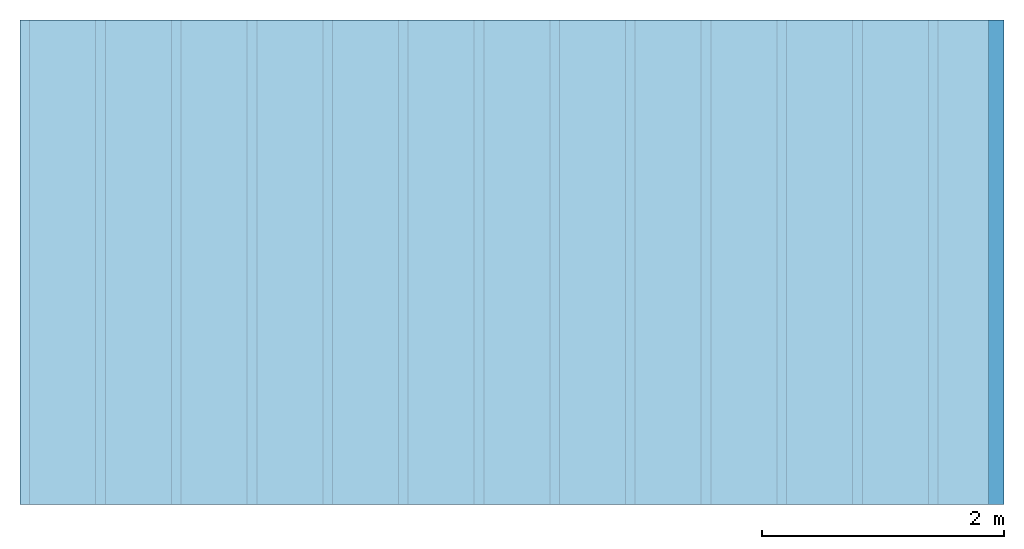
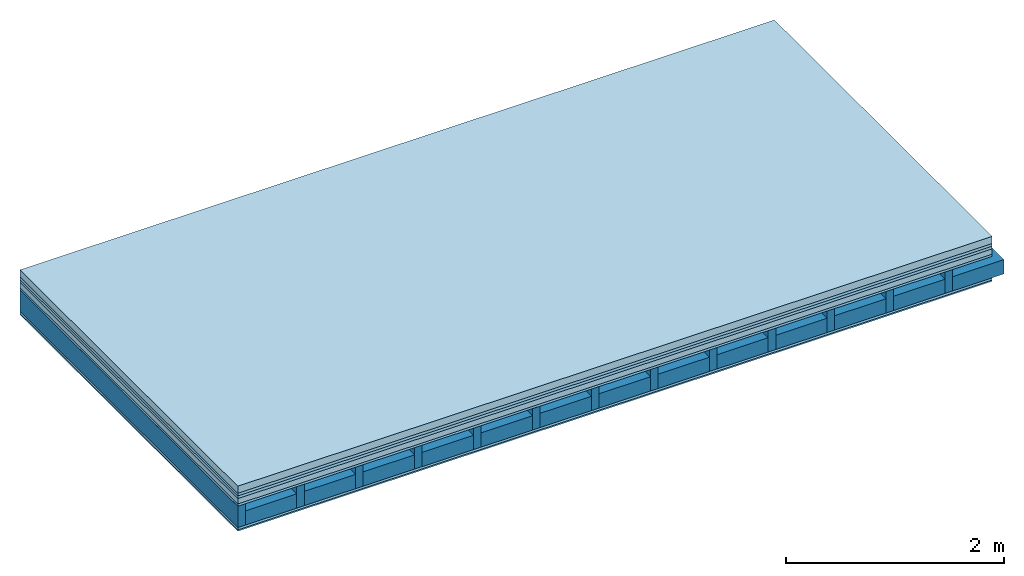
# One storey: 7 plates, 2 members, 1 element without a shape of its own.
"""IFC4 building model written with IfcOpenShell, lengths in metres."""

from ifc_helpers import new_model, si_unit, derived_unit, direction, frame, frame_2d, origin, origin_with_axes, place, context, project, spatial, rectangle, extrude, material, layer, layer_set, type_object, element, aggregate, save


model = new_model("IFC4")

# Units and contexts
plan_context = context("Plan", 3, precision=1e-05, world=origin(), true_north=direction((0.0, 1.0)))
model_context = context("Model", 3, precision=1e-05, world=origin(), true_north=direction((0.0, 1.0)))
ifc_project = project(units=[si_unit("LENGTHUNIT", "METRE"), derived_unit("SOUNDPRESSUREUNIT", [(si_unit("PRESSUREUNIT", "PASCAL", prefix="MICRO"), 0)]), si_unit("ENERGYUNIT", "JOULE", prefix="MEGA"), si_unit("MASSUNIT", "GRAM", prefix="KILO"), derived_unit("THERMALTRANSMITTANCEUNIT", [(si_unit("POWERUNIT", "WATT"), 1), (si_unit("AREAUNIT", "SQUARE_METRE"), -1), (si_unit("THERMODYNAMICTEMPERATUREUNIT", "KELVIN"), -1)]), derived_unit("AREADENSITYUNIT", [(si_unit("MASSUNIT", "GRAM", prefix="KILO"), 1), (si_unit("AREAUNIT", "SQUARE_METRE"), -1)]), derived_unit("USERDEFINED", [(si_unit("ENERGYUNIT", "JOULE", prefix="MEGA"), 1), (si_unit("AREAUNIT", "SQUARE_METRE"), -1)])], contexts=[plan_context, model_context])

# Site, building, storey
site = spatial("IfcSite", under=ifc_project)
building_placement = place(None, origin())
building = spatial("IfcBuilding", under=site, at=building_placement)
storey_placement = place(building_placement, origin())
storey = spatial("IfcBuildingStorey", under=building, at=storey_placement)

# Slab, members, plates
ifc_material_1 = material(Name="Cement screed", Category="04.006")
ifc_layer_1 = layer(ifc_material_1, 0.08, Name="On-material")
ifc_material_2 = material()
ifc_layer_2 = layer(ifc_material_2, 0.03, Name="Impact sound insulation")
ifc_material_3 = material()
ifc_layer_3 = layer(ifc_material_3, 0.03, Name="Additional insulation")
ifc_material_4 = material(Name="Cement panels, glued on sub-floor", Category="02.007")
ifc_layer_4 = layer(ifc_material_4, 0.06, Name="on Supporting structure")
ifc_material_5 = material(Category="07.001")
ifc_layer_5 = layer(ifc_material_5, 0.025, Name="Sub-floor")
ifc_material_6 = material(Name="Rigid, of the art")
ifc_layer_6 = layer(ifc_material_6, 0.0, Name="Bond")
ifc_layer_7 = layer(None, 0.24, Name="Supporting structure")
ifc_layer_8 = layer(ifc_material_6, 0.0, Name="Bond")
ifc_layer_9 = layer(ifc_material_5, 0.025, Name="Lower layer 1")
ifc_material_7 = material(Category="03.007")
ifc_layer_10 = layer(ifc_material_7, 0.015, Name="Lower 2nd layer")
ifc_layer_set = layer_set([ifc_layer_1, ifc_layer_2, ifc_layer_3, ifc_layer_4, ifc_layer_5, ifc_layer_6, ifc_layer_7, ifc_layer_8, ifc_layer_9, ifc_layer_10])
slab_type = type_object("IfcSlabType", Name="A0431", PredefinedType="NOTDEFINED", material=ifc_layer_set)
slab_placement = place(None, frame((0.0, 0.0, 0.0), z_axis=(0.0, 0.0, -1.0), x_axis=(1.0, 0.0, 0.0)))
slab = element("IfcSlab", 1, at=slab_placement, inside=storey, type_object=slab_type, material=ifc_layer_set, Name="Slab #1")
ifc_material_8 = material()
member_1_placement = place(slab_placement, origin())
member_1 = element("IfcMember", 2, at=member_1_placement, material=ifc_material_8, Name="Supporting structure", context=plan_context, shape_type="SweptSolid", body=[
    extrude(rectangle(XDim=0.08, YDim=0.24, at=frame_2d((0.04, 0.12), x_axis=(1.0, 0.0))), frame((0.0, 4.0, 0.225), z_axis=(0.0, -1.0, 0.0), x_axis=(1.0, 0.0, 0.0)), (0.0, 0.0, 1.0), 4.0),
    extrude(rectangle(XDim=0.08, YDim=0.24, at=frame_2d((0.04, 0.12), x_axis=(1.0, 0.0))), frame((0.625, 4.0, 0.225), z_axis=(0.0, -1.0, 0.0), x_axis=(1.0, 0.0, 0.0)), (0.0, 0.0, 1.0), 4.0),
    extrude(rectangle(XDim=0.08, YDim=0.24, at=frame_2d((0.04, 0.12), x_axis=(1.0, 0.0))), frame((1.25, 4.0, 0.225), z_axis=(0.0, -1.0, 0.0), x_axis=(1.0, 0.0, 0.0)), (0.0, 0.0, 1.0), 4.0),
    extrude(rectangle(XDim=0.08, YDim=0.24, at=frame_2d((0.04, 0.12), x_axis=(1.0, 0.0))), frame((1.875, 4.0, 0.225), z_axis=(0.0, -1.0, 0.0), x_axis=(1.0, 0.0, 0.0)), (0.0, 0.0, 1.0), 4.0),
    extrude(rectangle(XDim=0.08, YDim=0.24, at=frame_2d((0.04, 0.12), x_axis=(1.0, 0.0))), frame((2.5, 4.0, 0.225), z_axis=(0.0, -1.0, 0.0), x_axis=(1.0, 0.0, 0.0)), (0.0, 0.0, 1.0), 4.0),
    extrude(rectangle(XDim=0.08, YDim=0.24, at=frame_2d((0.04, 0.12), x_axis=(1.0, 0.0))), frame((3.125, 4.0, 0.225), z_axis=(0.0, -1.0, 0.0), x_axis=(1.0, 0.0, 0.0)), (0.0, 0.0, 1.0), 4.0),
    extrude(rectangle(XDim=0.08, YDim=0.24, at=frame_2d((0.04, 0.12), x_axis=(1.0, 0.0))), frame((3.75, 4.0, 0.225), z_axis=(0.0, -1.0, 0.0), x_axis=(1.0, 0.0, 0.0)), (0.0, 0.0, 1.0), 4.0),
    extrude(rectangle(XDim=0.08, YDim=0.24, at=frame_2d((0.04, 0.12), x_axis=(1.0, 0.0))), frame((4.375, 4.0, 0.225), z_axis=(0.0, -1.0, 0.0), x_axis=(1.0, 0.0, 0.0)), (0.0, 0.0, 1.0), 4.0),
    extrude(rectangle(XDim=0.08, YDim=0.24, at=frame_2d((0.04, 0.12), x_axis=(1.0, 0.0))), frame((5.0, 4.0, 0.225), z_axis=(0.0, -1.0, 0.0), x_axis=(1.0, 0.0, 0.0)), (0.0, 0.0, 1.0), 4.0),
    extrude(rectangle(XDim=0.08, YDim=0.24, at=frame_2d((0.04, 0.12), x_axis=(1.0, 0.0))), frame((5.625, 4.0, 0.225), z_axis=(0.0, -1.0, 0.0), x_axis=(1.0, 0.0, 0.0)), (0.0, 0.0, 1.0), 4.0),
    extrude(rectangle(XDim=0.08, YDim=0.24, at=frame_2d((0.04, 0.12), x_axis=(1.0, 0.0))), frame((6.25, 4.0, 0.225), z_axis=(0.0, -1.0, 0.0), x_axis=(1.0, 0.0, 0.0)), (0.0, 0.0, 1.0), 4.0),
    extrude(rectangle(XDim=0.08, YDim=0.24, at=frame_2d((0.04, 0.12), x_axis=(1.0, 0.0))), frame((6.875, 4.0, 0.225), z_axis=(0.0, -1.0, 0.0), x_axis=(1.0, 0.0, 0.0)), (0.0, 0.0, 1.0), 4.0),
    extrude(rectangle(XDim=0.08, YDim=0.24, at=frame_2d((0.04, 0.12), x_axis=(1.0, 0.0))), frame((7.5, 4.0, 0.225), z_axis=(0.0, -1.0, 0.0), x_axis=(1.0, 0.0, 0.0)), (0.0, 0.0, 1.0), 4.0),
])
ifc_material_9 = material()
member_2_placement = place(slab_placement, origin())
member_2 = element("IfcMember", 3, at=member_2_placement, material=ifc_material_9, Name="Cavity", context=plan_context, shape_type="SweptSolid", body=[
    extrude(rectangle(XDim=0.545, YDim=0.16, at=frame_2d((0.2725, 0.08), x_axis=(1.0, 0.0))), frame((0.08, 4.0, 0.305), z_axis=(0.0, -1.0, 0.0), x_axis=(1.0, 0.0, 0.0)), (0.0, 0.0, 1.0), 4.0),
    extrude(rectangle(XDim=0.545, YDim=0.16, at=frame_2d((0.2725, 0.08), x_axis=(1.0, 0.0))), frame((0.705, 4.0, 0.305), z_axis=(0.0, -1.0, 0.0), x_axis=(1.0, 0.0, 0.0)), (0.0, 0.0, 1.0), 4.0),
    extrude(rectangle(XDim=0.545, YDim=0.16, at=frame_2d((0.2725, 0.08), x_axis=(1.0, 0.0))), frame((1.33, 4.0, 0.305), z_axis=(0.0, -1.0, 0.0), x_axis=(1.0, 0.0, 0.0)), (0.0, 0.0, 1.0), 4.0),
    extrude(rectangle(XDim=0.545, YDim=0.16, at=frame_2d((0.2725, 0.08), x_axis=(1.0, 0.0))), frame((1.955, 4.0, 0.305), z_axis=(0.0, -1.0, 0.0), x_axis=(1.0, 0.0, 0.0)), (0.0, 0.0, 1.0), 4.0),
    extrude(rectangle(XDim=0.545, YDim=0.16, at=frame_2d((0.2725, 0.08), x_axis=(1.0, 0.0))), frame((2.58, 4.0, 0.305), z_axis=(0.0, -1.0, 0.0), x_axis=(1.0, 0.0, 0.0)), (0.0, 0.0, 1.0), 4.0),
    extrude(rectangle(XDim=0.545, YDim=0.16, at=frame_2d((0.2725, 0.08), x_axis=(1.0, 0.0))), frame((3.205, 4.0, 0.305), z_axis=(0.0, -1.0, 0.0), x_axis=(1.0, 0.0, 0.0)), (0.0, 0.0, 1.0), 4.0),
    extrude(rectangle(XDim=0.545, YDim=0.16, at=frame_2d((0.2725, 0.08), x_axis=(1.0, 0.0))), frame((3.83, 4.0, 0.305), z_axis=(0.0, -1.0, 0.0), x_axis=(1.0, 0.0, 0.0)), (0.0, 0.0, 1.0), 4.0),
    extrude(rectangle(XDim=0.545, YDim=0.16, at=frame_2d((0.2725, 0.08), x_axis=(1.0, 0.0))), frame((4.455, 4.0, 0.305), z_axis=(0.0, -1.0, 0.0), x_axis=(1.0, 0.0, 0.0)), (0.0, 0.0, 1.0), 4.0),
    extrude(rectangle(XDim=0.545, YDim=0.16, at=frame_2d((0.2725, 0.08), x_axis=(1.0, 0.0))), frame((5.08, 4.0, 0.305), z_axis=(0.0, -1.0, 0.0), x_axis=(1.0, 0.0, 0.0)), (0.0, 0.0, 1.0), 4.0),
    extrude(rectangle(XDim=0.545, YDim=0.16, at=frame_2d((0.2725, 0.08), x_axis=(1.0, 0.0))), frame((5.705, 4.0, 0.305), z_axis=(0.0, -1.0, 0.0), x_axis=(1.0, 0.0, 0.0)), (0.0, 0.0, 1.0), 4.0),
    extrude(rectangle(XDim=0.545, YDim=0.16, at=frame_2d((0.2725, 0.08), x_axis=(1.0, 0.0))), frame((6.33, 4.0, 0.305), z_axis=(0.0, -1.0, 0.0), x_axis=(1.0, 0.0, 0.0)), (0.0, 0.0, 1.0), 4.0),
    extrude(rectangle(XDim=0.545, YDim=0.16, at=frame_2d((0.2725, 0.08), x_axis=(1.0, 0.0))), frame((6.955, 4.0, 0.305), z_axis=(0.0, -1.0, 0.0), x_axis=(1.0, 0.0, 0.0)), (0.0, 0.0, 1.0), 4.0),
    extrude(rectangle(XDim=0.545, YDim=0.16, at=frame_2d((0.2725, 0.08), x_axis=(1.0, 0.0))), frame((7.58, 4.0, 0.305), z_axis=(0.0, -1.0, 0.0), x_axis=(1.0, 0.0, 0.0)), (0.0, 0.0, 1.0), 4.0),
])
plate_1_placement = place(slab_placement, origin())
plate_1 = element("IfcPlate", 4, at=plate_1_placement, material=ifc_material_1, Name="On-material", context=plan_context, shape_type="SweptSolid", body=[
    extrude(rectangle(XDim=8.0, YDim=4.0, at=frame_2d((4.0, 2.0), x_axis=(1.0, 0.0))), origin_with_axes(), (0.0, 0.0, 1.0), 0.08),
])
plate_2_placement = place(slab_placement, origin())
plate_2 = element("IfcPlate", 5, at=plate_2_placement, material=ifc_material_2, Name="Impact sound insulation", context=plan_context, shape_type="SweptSolid", body=[
    extrude(rectangle(XDim=8.0, YDim=4.0, at=frame_2d((4.0, 2.0), x_axis=(1.0, 0.0))), frame((0.0, 0.0, 0.08), z_axis=(0.0, 0.0, 1.0), x_axis=(1.0, 0.0, 0.0)), (0.0, 0.0, 1.0), 0.03),
])
plate_3_placement = place(slab_placement, origin())
plate_3 = element("IfcPlate", 6, at=plate_3_placement, material=ifc_material_3, Name="Additional insulation", context=plan_context, shape_type="SweptSolid", body=[
    extrude(rectangle(XDim=8.0, YDim=4.0, at=frame_2d((4.0, 2.0), x_axis=(1.0, 0.0))), frame((0.0, 0.0, 0.11), z_axis=(0.0, 0.0, 1.0), x_axis=(1.0, 0.0, 0.0)), (0.0, 0.0, 1.0), 0.03),
])
plate_4_placement = place(slab_placement, origin())
plate_4 = element("IfcPlate", 7, at=plate_4_placement, material=ifc_material_4, Name="on Supporting structure", context=plan_context, shape_type="SweptSolid", body=[
    extrude(rectangle(XDim=8.0, YDim=4.0, at=frame_2d((4.0, 2.0), x_axis=(1.0, 0.0))), frame((0.0, 0.0, 0.14), z_axis=(0.0, 0.0, 1.0), x_axis=(1.0, 0.0, 0.0)), (0.0, 0.0, 1.0), 0.06),
])
plate_5_placement = place(slab_placement, origin())
plate_5 = element("IfcPlate", 8, at=plate_5_placement, material=ifc_material_5, Name="Sub-floor", context=plan_context, shape_type="SweptSolid", body=[
    extrude(rectangle(XDim=8.0, YDim=4.0, at=frame_2d((4.0, 2.0), x_axis=(1.0, 0.0))), frame((0.0, 0.0, 0.2), z_axis=(0.0, 0.0, 1.0), x_axis=(1.0, 0.0, 0.0)), (0.0, 0.0, 1.0), 0.025),
])
plate_6_placement = place(slab_placement, origin())
plate_6 = element("IfcPlate", 9, at=plate_6_placement, material=ifc_material_5, Name="Lower layer 1", context=plan_context, shape_type="SweptSolid", body=[
    extrude(rectangle(XDim=8.0, YDim=4.0, at=frame_2d((4.0, 2.0), x_axis=(1.0, 0.0))), frame((0.0, 0.0, 0.465), z_axis=(0.0, 0.0, 1.0), x_axis=(1.0, 0.0, 0.0)), (0.0, 0.0, 1.0), 0.025),
])
plate_7_placement = place(slab_placement, origin())
plate_7 = element("IfcPlate", 10, at=plate_7_placement, material=ifc_material_7, Name="Lower 2nd layer", context=plan_context, shape_type="SweptSolid", body=[
    extrude(rectangle(XDim=8.0, YDim=4.0, at=frame_2d((4.0, 2.0), x_axis=(1.0, 0.0))), frame((0.0, 0.0, 0.49), z_axis=(0.0, 0.0, 1.0), x_axis=(1.0, 0.0, 0.0)), (0.0, 0.0, 1.0), 0.015),
])
aggregate(slab, [plate_1, plate_2, plate_3, plate_4, plate_5, member_1, member_2, plate_6, plate_7])

save(model, "model.ifc")
